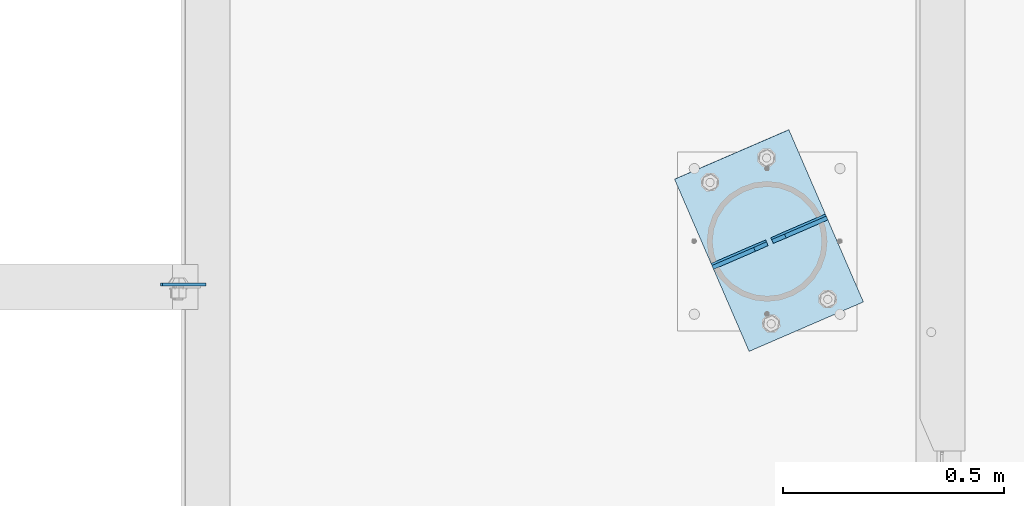
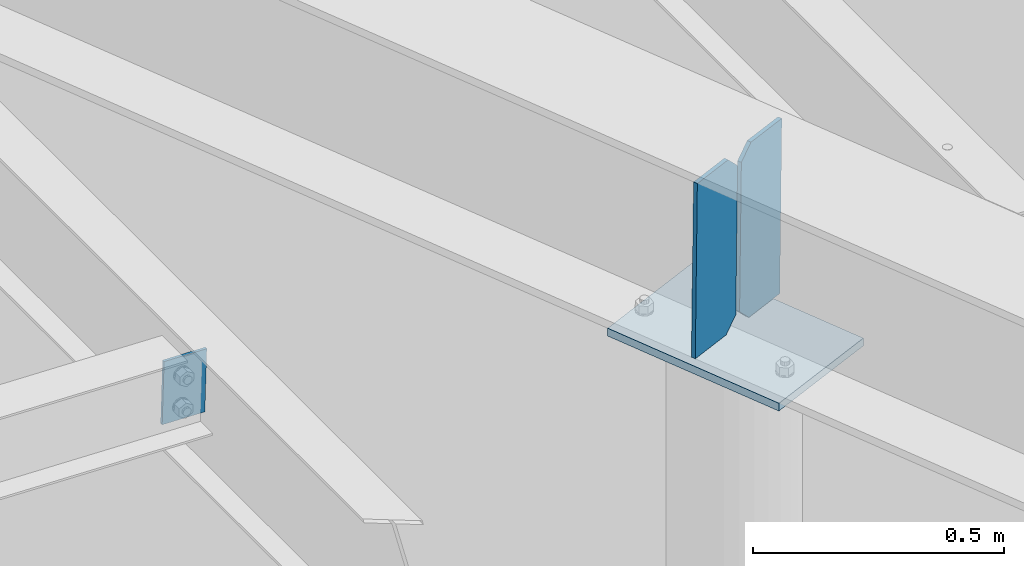
# One storey, part 1657 of 1763: 4 plates, 3 elements without a shape of their own.
"""IFC2X3 building model written with IfcOpenShell, lengths in millimetres."""

import ifcopenshell
import ifcopenshell.guid

model = None  # the IFC model being written
_history = None  # IfcOwnerHistory: only IFC2X3 demands one
_inside = {}  # id of a spatial element -> (the spatial element, [elements in it])
_under = {}  # id of a project, library or spatial element -> (it, [spatial elements below it])
_declared = {}  # id of a project -> (the project, [libraries it declares])
_typed = {}  # id of a type object -> (the type object, [elements of that type])
_made_of = {}  # id of a material, layer set ... -> (it, [elements and type objects made of it])


def new_model(schema):
    """Start an empty IFC model of exactly this schema.

    Asked for "IFC4X3", IfcOpenShell would pick the latest addendum, in which some entities
    have other attributes; the version numbers below select the first issue.
    IFC2X3 requires an IfcOwnerHistory on every rooted entity: one is made here for all.
    """
    global model, _history
    if schema == "IFC4X3":
        model = ifcopenshell.file(schema_version=(4, 3, 0, 0))
    else:
        model = ifcopenshell.file(schema=schema)
    _inside.clear()
    _under.clear()
    _declared.clear()
    _typed.clear()
    _made_of.clear()
    _history = None
    if model.schema == "IFC2X3":
        org = make("IfcOrganization", Name="unknown")
        user = make(
            "IfcPersonAndOrganization",
            ThePerson=make("IfcPerson", FamilyName="unknown"),
            TheOrganization=org,
        )
        app = make(
            "IfcApplication",
            ApplicationDeveloper=org,
            Version="unknown",
            ApplicationFullName="unknown",
            ApplicationIdentifier="unknown",
        )
        _history = make(
            "IfcOwnerHistory",
            OwningUser=user,
            OwningApplication=app,
            ChangeAction="ADDED",
            CreationDate=0,
        )
    return model


def make(cls, **values):
    """One entity of the class cls with the attributes given. An attribute that is None is left unset."""
    return model.create_entity(
        cls, **{name: value for name, value in values.items() if value is not None}
    )


def rooted(cls, **values):
    """An entity with a GlobalId (a new one), such as an element, a storey or a relation."""
    return make(cls, GlobalId=ifcopenshell.guid.new(), OwnerHistory=_history, **values)


def si_unit(unit_type, name, prefix=None):
    """IfcSIUnit, for example si_unit("LENGTHUNIT", "METRE", prefix="MILLI")."""
    return make("IfcSIUnit", UnitType=unit_type, Prefix=prefix, Name=name)


def assignment(units):
    """IfcUnitAssignment: the units of a project."""
    return None if units is None else make("IfcUnitAssignment", Units=units)


def point(xyz):
    """IfcCartesianPoint."""
    return None if xyz is None else make("IfcCartesianPoint", Coordinates=xyz)


def direction(xyz):
    """IfcDirection."""
    return None if xyz is None else make("IfcDirection", DirectionRatios=xyz)


def frame(location, z_axis=None, x_axis=None):
    """IfcAxis2Placement3D, a coordinate frame: its origin and axes. An axis left out is left unset."""
    return make(
        "IfcAxis2Placement3D",
        Location=point(location),
        Axis=direction(z_axis),
        RefDirection=direction(x_axis),
    )


def origin_with_axes():
    """The frame at (0, 0, 0) with the z axis (0, 0, 1) and the x axis (1, 0, 0) written out."""
    return frame((0.0, 0.0, 0.0), z_axis=(0.0, 0.0, 1.0), x_axis=(1.0, 0.0, 0.0))


def place(relative_to, where):
    """IfcLocalPlacement: puts the frame where relative to a parent placement (None: the world)."""
    return make(
        "IfcLocalPlacement", PlacementRelTo=relative_to, RelativePlacement=where
    )


def context(
    kind, dimensions, precision=None, world=None, true_north=None, identifier=None
):
    """IfcGeometricRepresentationContext, for example the 3D "Model" context."""
    return make(
        "IfcGeometricRepresentationContext",
        ContextIdentifier=identifier,
        ContextType=kind,
        CoordinateSpaceDimension=dimensions,
        Precision=precision,
        WorldCoordinateSystem=world,
        TrueNorth=true_north,
    )


def subcontext(parent, identifier, kind, view, scale=None):
    """IfcGeometricRepresentationSubContext, for example "Body" below "Model"."""
    return make(
        "IfcGeometricRepresentationSubContext",
        ContextIdentifier=identifier,
        ContextType=kind,
        ParentContext=parent,
        TargetScale=scale,
        TargetView=view,
    )


def project(units=None, contexts=None):
    """IfcProject with its units and contexts."""
    return rooted(
        "IfcProject",
        Name="project",
        RepresentationContexts=contexts,
        UnitsInContext=assignment(units),
    )


def spatial(cls, under=None, at=None, **own):
    """A site, building, storey or space (cls), placed at a placement, below another one or the project."""
    s = rooted(cls, ObjectPlacement=at, **own)
    if under is not None:
        _under.setdefault(under.id(), (under, []))[1].append(s)
    return s


def faces_of(points, faces, orient=None, outer=None):
    """IfcFace entities. A face is a list of loops; a loop is a list of indices into points, from 0.

    orient and outer hold one flag for each loop. By default every Orientation is true, the
    first loop of a face is its IfcFaceOuterBound and the others are IfcFaceBound.
    """
    made = []
    for i, loops in enumerate(faces):
        bounds = []
        for j, loop in enumerate(loops):
            is_outer = j == 0 if outer is None else outer[i][j]
            bounds.append(
                make(
                    "IfcFaceOuterBound" if is_outer else "IfcFaceBound",
                    Bound=make("IfcPolyLoop", Polygon=[points[k] for k in loop]),
                    Orientation=True if orient is None else orient[i][j],
                )
            )
        made.append(make("IfcFace", Bounds=bounds))
    return made


def faceted_brep(points, faces, orient=None, outer=None, voids=None):
    """IfcFacetedBrep: a solid bounded by flat faces; with voids (closed shells), ...WithVoids."""
    shared = [point(p) for p in points]
    hull = make("IfcClosedShell", CfsFaces=faces_of(shared, faces, orient, outer))
    if voids is None:
        return make("IfcFacetedBrep", Outer=hull)
    return make(
        "IfcFacetedBrepWithVoids",
        Outer=hull,
        Voids=[
            make(cls, CfsFaces=faces_of(shared, fs, o, b)) for cls, fs, o, b in voids
        ],
    )


def shape(context_of_items, identifier, shape_type, items):
    """IfcShapeRepresentation: the items that make up one representation, for example the "Body"."""
    return make(
        "IfcShapeRepresentation",
        ContextOfItems=context_of_items,
        RepresentationIdentifier=identifier,
        RepresentationType=shape_type,
        Items=items,
    )


def material(Name=None, Category=None):
    """IfcMaterial."""
    return make("IfcMaterial", Name=Name, Category=Category)


def made_of(thing, what):
    """Note that an element or type object is made of a material, layer set ...; save() writes the relation."""
    if what is not None:
        _made_of.setdefault(what.id(), (what, []))[1].append(thing)
    return thing


def type_object(cls, material=None, **own):
    """A type object (cls), such as IfcWallType, which elements share."""
    return made_of(rooted(cls, **own), material)


def element(
    cls,
    number,
    at=None,
    inside=None,
    cuts=None,
    type_object=None,
    material=None,
    context=None,
    identifier="Body",
    shape_type=None,
    held_by="IfcProductDefinitionShape",
    body=None,
    shapes=None,
    **own,
):
    """One element of the class cls, such as IfcWall. Its Tag is "e" and its number.

    at: its placement. inside: the storey or other place that contains it. cuts: it is an
    opening in that element (IfcRelVoidsElement). A single representation is given by context,
    identifier, shape_type and body (its items); several are given by shapes. held_by: the class
    of the entity that holds the representations. save() writes the other relations.
    """
    e = rooted(cls, Tag="e%d" % number, ObjectPlacement=at, **own)
    if body is not None:
        shapes = [shape(context, identifier, shape_type, body)]
    if shapes is not None:
        e.Representation = make(held_by, Representations=shapes)
    if inside is not None:
        _inside.setdefault(inside.id(), (inside, []))[1].append(e)
    if cuts is not None:
        rooted(
            "IfcRelVoidsElement", RelatingBuildingElement=cuts, RelatedOpeningElement=e
        )
    if type_object is not None:
        _typed.setdefault(type_object.id(), (type_object, []))[1].append(e)
    return made_of(e, material)


def aggregate(whole, parts):
    """IfcRelAggregates: a whole, such as a stair, and the parts it consists of."""
    return rooted("IfcRelAggregates", RelatingObject=whole, RelatedObjects=parts)


def save(model, path):
    """Write the relations noted so far, then the file.

    IfcRelAggregates (storeys below a building ...), IfcRelContainedInSpatialStructure (elements
    in a storey), IfcRelDefinesByType, IfcRelAssociatesMaterial and IfcRelDeclares: one each for
    every whole, place, type object, material and project.
    """
    for whole, parts in _under.values():
        aggregate(whole, parts)
    for where, things in _inside.values():
        rooted(
            "IfcRelContainedInSpatialStructure",
            RelatedElements=things,
            RelatingStructure=where,
        )
    for kind, things in _typed.values():
        rooted("IfcRelDefinesByType", RelatedObjects=things, RelatingType=kind)
    for what, things in _made_of.values():
        rooted("IfcRelAssociatesMaterial", RelatedObjects=things, RelatingMaterial=what)
    for by, libraries in _declared.values():
        rooted("IfcRelDeclares", RelatingContext=by, RelatedDefinitions=libraries)
    model.write(path)


model = new_model("IFC2X3")

# Units and contexts
model_context = context("Model", 3, precision=1e-05, world=origin_with_axes())
body_context = subcontext(model_context, "Body", "Model", "MODEL_VIEW")
ifc_project = project(units=[si_unit("LENGTHUNIT", "METRE", prefix="MILLI"), si_unit("AREAUNIT", "SQUARE_METRE"), si_unit("VOLUMEUNIT", "CUBIC_METRE"), si_unit("MASSUNIT", "GRAM", prefix="KILO"), si_unit("TIMEUNIT", "SECOND"), si_unit("PLANEANGLEUNIT", "RADIAN"), si_unit("SOLIDANGLEUNIT", "STERADIAN"), si_unit("THERMODYNAMICTEMPERATUREUNIT", "DEGREE_CELSIUS"), si_unit("LUMINOUSINTENSITYUNIT", "LUMEN")], contexts=[model_context])

# Site, building, storey
site_placement = place(None, origin_with_axes())
site = spatial("IfcSite", under=ifc_project, at=site_placement, CompositionType="ELEMENT")
building_placement = place(site_placement, origin_with_axes())
building = spatial("IfcBuilding", under=site, at=building_placement, Name="Undefined", CompositionType="ELEMENT")
storey_placement = place(building_placement, origin_with_axes())
storey = spatial("IfcBuildingStorey", under=building, at=storey_placement, Name="Undefined", CompositionType="ELEMENT", Elevation=0.0)

# Assembly, plate
assembly_1_placement = place(storey_placement, origin_with_axes())
assembly_1 = element("IfcElementAssembly", 1, at=assembly_1_placement, inside=storey, Name="BEAM", AssemblyPlace="NOTDEFINED", PredefinedType="RIGID_FRAME")
ifc_material = material(Name="STEEL/A36")
plate_type_1 = type_object("IfcPlateType", PredefinedType="NOTDEFINED")
plate_1_placement = place(assembly_1_placement, frame((-48005.8701264998, 65580.2818847656, 12664.3937133307), z_axis=(-0.999566657934176, 0.0, 0.02943630999806), x_axis=(-0.0294363099980781, 0.0, -0.999566657934176)))
plate_1 = element("IfcPlate", 2, at=plate_1_placement, type_object=plate_type_1, material=ifc_material, Name="PLATE", context=body_context, shape_type="Brep", body=[
    faceted_brep([(1.81898940354586e-12, -3.17500000000291, 0.0), (-2.52839527092874e-10, -3.17500000000001, 98.4250000002357), (4.17785486206412e-08, 3.17500000000001, 98.425000000243), (-1.81898940354586e-12, 3.17499999997381, 0.0), (152.399993896475, -3.17500000000291, 98.4250030515323), (152.399993896475, 3.17500000000291, 98.4250030515323), (152.399993896484, -3.17500000000291, 0.0), (152.399993896484, 3.17500000000291, 0.0)], [[[0, 1, 2, 3]], [[1, 4, 5, 2]], [[4, 6, 7, 5]], [[6, 0, 3, 7]], [[5, 7, 3, 2]], [[6, 4, 1, 0]]]),
])
aggregate(assembly_1, [plate_1])

# Assembly, plates
assembly_2_placement = place(storey_placement, origin_with_axes())
assembly_2 = element("IfcElementAssembly", 3, at=assembly_2_placement, inside=storey, Name="BEAM", AssemblyPlace="NOTDEFINED", PredefinedType="RIGID_FRAME")
plate_type_2 = type_object("IfcPlateType", PredefinedType="NOTDEFINED")
plate_2_placement = place(assembly_2_placement, frame((-46597.5162253538, 65731.0866321206, 12640.5586835494), z_axis=(-0.00474172557303245, 0.010963753745993, -0.999928653526034), x_axis=(-0.917837428282059, -0.396956490367113, -2.68846633844078e-12)))
plate_2 = element("IfcPlate", 4, at=plate_2_placement, type_object=plate_type_2, material=ifc_material, Name="PLATE", context=body_context, shape_type="Brep", body=[
    faceted_brep([(0.0, -4.76249999999982, 0.0), (0.0, -4.76249999999709, 428.625), (0.0, 4.76249999999709, 428.625), (0.0, 4.76249999999982, 0.0), (103.187500000269, -4.7625000035041, 428.624999999853), (103.187500000306, 4.76249999647553, 428.624999999851), (134.937500000353, -4.76250000331493, 396.874999999862), (134.937500000386, 4.7624999966647, 396.874999999858), (134.937500000324, -4.76250000052096, 31.7499999997162), (134.937500000353, 4.76249999945867, 31.7499999997126), (103.187500000244, -4.76250000021537, -2.11002770811319e-10), (103.187500000269, 4.76249999976426, -2.12821760214865e-10)], [[[0, 1, 2, 3]], [[1, 4, 5, 2]], [[4, 6, 7, 5]], [[6, 8, 9, 7]], [[8, 10, 11, 9]], [[10, 0, 3, 11]], [[5, 7, 9, 11, 3, 2]], [[10, 8, 6, 4, 1, 0]]]),
])
plate_3_placement = place(assembly_2_placement, frame((-46856.8741366354, 65618.9166518733, 12640.5586835494), z_axis=(-0.00474172557303245, 0.010963753745993, -0.999928653526034), x_axis=(0.917837428282057, 0.396956490367119, 2.68846633844077e-12)))
plate_3 = element("IfcPlate", 5, at=plate_3_placement, type_object=plate_type_2, material=ifc_material, Name="PLATE", context=body_context, shape_type="Brep", body=[
    faceted_brep([(0.0, -4.76249999999982, 0.0), (0.0, -4.76249999999709, 428.625), (0.0, 4.76249999999709, 428.625), (0.0, 4.76249999999982, 0.0), (103.187500000269, -4.7625000035041, 428.624999999853), (103.187500000306, 4.76249999647553, 428.624999999851), (134.937500000353, -4.76250000331493, 396.874999999862), (134.937500000386, 4.7624999966647, 396.874999999858), (134.937500000324, -4.76250000052096, 31.7499999997162), (134.937500000353, 4.76249999945867, 31.7499999997126), (103.187500000244, -4.76250000021537, -2.11002770811319e-10), (103.187500000269, 4.76249999976426, -2.12821760214865e-10)], [[[0, 1, 2, 3]], [[1, 4, 5, 2]], [[4, 6, 7, 5]], [[6, 8, 9, 7]], [[8, 10, 11, 9]], [[10, 0, 3, 11]], [[5, 7, 9, 11, 3, 2]], [[10, 8, 6, 4, 1, 0]]]),
])
aggregate(assembly_2, [plate_2, plate_3])

# Assembly, plate
assembly_3_placement = place(storey_placement, origin_with_axes())
assembly_3 = element("IfcElementAssembly", 6, at=assembly_3_placement, inside=storey, Name="COLUMN", AssemblyPlace="NOTDEFINED", PredefinedType="RIGID_FRAME")
plate_type_3 = type_object("IfcPlateType", PredefinedType="NOTDEFINED")
plate_4_placement = place(assembly_3_placement, frame((-46943.4824234359, 65819.158252156, 12186.0300427689), z_axis=(0.396925948629433, -0.917766810656048, -0.01240453799426), x_axis=(0.917837428282057, 0.396956490367119, 2.68846633844077e-12)))
plate_4 = element("IfcPlate", 7, at=plate_4_placement, type_object=plate_type_3, material=ifc_material, Name="PLATE", context=body_context, shape_type="Brep", body=[
    faceted_brep([(0.0, -9.52500000000146, 0.0), (0.174324185969454, -9.52500000003965, 425.447631836825), (0.174324185925798, 9.52499999996689, 425.447631836767), (0.0, 9.52500000000146, 0.0), (282.585876466885, -9.52500000004693, 425.447631836229), (282.585876466834, 9.52499999995962, 425.44763183617), (282.411560059354, -9.52500000000873, 1.01863406598568e-10), (282.411560059314, 9.524999999996, 2.91038304567337e-11)], [[[0, 1, 2, 3]], [[1, 4, 5, 2]], [[4, 6, 7, 5]], [[6, 0, 3, 7]], [[5, 7, 3, 2]], [[6, 4, 1, 0]]]),
])
aggregate(assembly_3, [plate_4])

save(model, "model.ifc")
